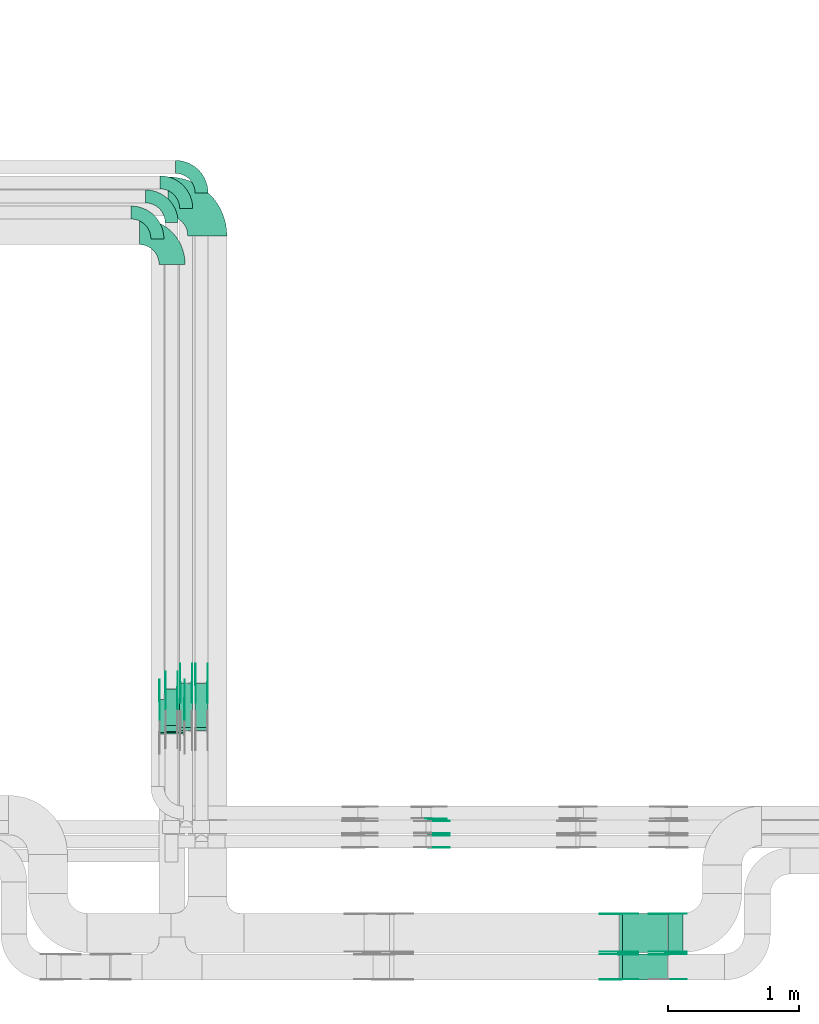
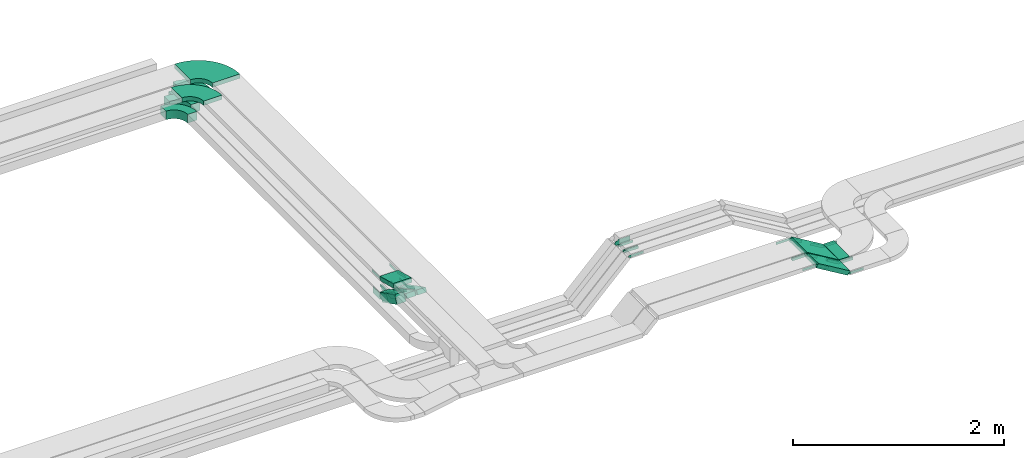
# One storey, part 17 of 19: 42 flow fittings, 7 flow segments.
"""IFC2X3 building model written with IfcOpenShell, lengths in millimetres."""

from ifc_helpers import new_model, entity, si_unit, converted_unit, derived_unit, direction, frame, frame_2d, origin, origin_2d_with_axis, place, context, subcontext, project, spatial, polyline, circle_curve, parameter, trimmed, segment, composite_curve, rectangle, outline, extrude, source, transform, mapped, material, type_object, type_shapes, element, save


model = new_model("IFC2X3")

# Units and contexts
model_context = context("Model", 3, precision=0.01, world=origin(), true_north=direction((6.12303176911189e-17, 1.0)))
body_context = subcontext(model_context, "Body", "Model", "MODEL_VIEW")
ifc_project = project(units=[si_unit("LENGTHUNIT", "METRE", prefix="MILLI"), si_unit("AREAUNIT", "SQUARE_METRE"), si_unit("VOLUMEUNIT", "CUBIC_METRE"), converted_unit("PLANEANGLEUNIT", "DEGREE", entity("IfcRatioMeasure", 0.0174532925199433), si_unit("PLANEANGLEUNIT", "RADIAN"), dimensions=[0, 0, 0, 0, 0, 0, 0]), si_unit("MASSUNIT", "GRAM", prefix="KILO"), derived_unit("MASSDENSITYUNIT", [(si_unit("MASSUNIT", "GRAM", prefix="KILO"), 1), (si_unit("LENGTHUNIT", "METRE"), -3)]), derived_unit("MOMENTOFINERTIAUNIT", [(si_unit("LENGTHUNIT", "METRE"), 4)]), si_unit("TIMEUNIT", "SECOND"), si_unit("FREQUENCYUNIT", "HERTZ"), si_unit("THERMODYNAMICTEMPERATUREUNIT", "DEGREE_CELSIUS"), derived_unit("THERMALTRANSMITTANCEUNIT", [(si_unit("MASSUNIT", "GRAM", prefix="KILO"), 1), (si_unit("THERMODYNAMICTEMPERATUREUNIT", "KELVIN"), -1), (si_unit("TIMEUNIT", "SECOND"), -3)]), derived_unit("VOLUMETRICFLOWRATEUNIT", [(si_unit("LENGTHUNIT", "METRE"), 3), (si_unit("TIMEUNIT", "SECOND"), -1)]), derived_unit("MASSFLOWRATEUNIT", [(si_unit("MASSUNIT", "GRAM", prefix="KILO"), 1), (si_unit("TIMEUNIT", "SECOND"), -1)]), derived_unit("ROTATIONALFREQUENCYUNIT", [(si_unit("TIMEUNIT", "SECOND"), -1)]), si_unit("ELECTRICCURRENTUNIT", "AMPERE"), si_unit("ELECTRICVOLTAGEUNIT", "VOLT"), si_unit("POWERUNIT", "WATT"), si_unit("FORCEUNIT", "NEWTON", prefix="KILO"), si_unit("ILLUMINANCEUNIT", "LUX"), si_unit("LUMINOUSFLUXUNIT", "LUMEN"), si_unit("LUMINOUSINTENSITYUNIT", "CANDELA"), derived_unit("USERDEFINED", [(si_unit("MASSUNIT", "GRAM", prefix="KILO"), -1), (si_unit("LENGTHUNIT", "METRE"), -2), (si_unit("TIMEUNIT", "SECOND"), 3), (si_unit("LUMINOUSFLUXUNIT", "LUMEN"), 1)]), derived_unit("LINEARVELOCITYUNIT", [(si_unit("LENGTHUNIT", "METRE"), 1), (si_unit("TIMEUNIT", "SECOND"), -1)]), si_unit("PRESSUREUNIT", "PASCAL"), derived_unit("USERDEFINED", [(si_unit("LENGTHUNIT", "METRE"), -2), (si_unit("MASSUNIT", "GRAM", prefix="KILO"), 1), (si_unit("TIMEUNIT", "SECOND"), -2)]), derived_unit("LINEARFORCEUNIT", [(si_unit("MASSUNIT", "GRAM", prefix="KILO"), 1), (si_unit("LENGTHUNIT", "METRE"), 1), (si_unit("TIMEUNIT", "SECOND"), -2), (si_unit("LENGTHUNIT", "METRE"), -1)]), derived_unit("PLANARFORCEUNIT", [(si_unit("MASSUNIT", "GRAM", prefix="KILO"), 1), (si_unit("LENGTHUNIT", "METRE"), 1), (si_unit("TIMEUNIT", "SECOND"), -2), (si_unit("LENGTHUNIT", "METRE"), -2)])], contexts=[model_context])

# Site, building, storey
site_placement = place(None, origin())
site = spatial("IfcSite", under=ifc_project, at=site_placement, CompositionType="ELEMENT")
building_placement = place(site_placement, origin())
building = spatial("IfcBuilding", under=site, at=building_placement, CompositionType="ELEMENT")
storey_placement = place(building_placement, frame((0.0, 0.0, 12000.0)))
storey = spatial("IfcBuildingStorey", under=building, at=storey_placement, CompositionType="ELEMENT", Elevation=12000.0)

# Flow segments
cable_carrier_segment_type = type_object("IfcCableCarrierSegmentType", PredefinedType="CABLETRAYSEGMENT")
flow_segment_1_placement = place(storey_placement, frame((60138.97, 10518.86, 2511.79)))
element("IfcFlowSegment", 1, at=flow_segment_1_placement, inside=storey, type_object=cable_carrier_segment_type, context=body_context, shape_type="SweptSolid", body=[
    extrude(rectangle(XDim=99.9999999999996, YDim=313.488330030498, at=frame_2d((0.0, 0.0), x_axis=(0.0, 1.0))), frame((0.0, 162.36, 115.71), z_axis=(1.0, 0.0, 0.0), x_axis=(0.0, -0.891006524188386, 0.453990499739511)), (0.0, 0.0, 1.0), 100.000000000003),
])
flow_segment_2_placement = place(storey_placement, frame((60250.78, 10524.87, 2506.34)))
element("IfcFlowSegment", 2, at=flow_segment_2_placement, inside=storey, type_object=cable_carrier_segment_type, context=body_context, shape_type="SweptSolid", body=[
    extrude(rectangle(XDim=50.0000000000023, YDim=380.5594995989, at=frame_2d((0.0, 0.0), x_axis=(0.0, 1.0))), frame((0.0, 180.89, 108.66), z_axis=(1.0, 0.0, 0.0), x_axis=(0.0, -0.891006524188355, 0.453990499739573)), (0.0, 0.0, 1.0), 99.9999999999946),
])
flow_segment_3_placement = place(storey_placement, frame((60368.35, 10524.87, 2506.34)))
element("IfcFlowSegment", 3, at=flow_segment_3_placement, inside=storey, type_object=cable_carrier_segment_type, context=body_context, shape_type="SweptSolid", body=[
    extrude(rectangle(XDim=50.0000000000023, YDim=380.559499598904, at=frame_2d((0.0, 0.0), x_axis=(0.0, 1.0))), frame((0.0, 180.89, 108.66), z_axis=(1.0, 0.0, 0.0), x_axis=(0.0, -0.891006524188357, 0.453990499739568)), (0.0, 0.0, 1.0), 99.9999999999945),
])
flow_segment_4_placement = place(storey_placement, frame((60092.55, 10497.93, 2802.1)))
element("IfcFlowSegment", 4, at=flow_segment_4_placement, inside=storey, type_object=cable_carrier_segment_type, context=body_context, shape_type="SweptSolid", body=[
    extrude(rectangle(XDim=49.999999999998, YDim=260.823386500712, at=frame_2d((0.0, 0.0), x_axis=(0.0, 1.0))), frame((0.0, 132.44, 57.9), z_axis=(1.0, 0.0, 0.0), x_axis=(0.0, -0.965925826289048, 0.258819045102596)), (0.0, 0.0, 1.0), 200.000000000006),
])
flow_segment_5_placement = place(storey_placement, frame((63618.5, 8824.99, 2808.17)))
element("IfcFlowSegment", 5, at=flow_segment_5_placement, inside=storey, type_object=cable_carrier_segment_type, context=body_context, shape_type="SweptSolid", body=[
    extrude(rectangle(XDim=49.9999999999925, YDim=299.999999999999, at=frame_2d((0.0, 0.0), x_axis=(0.0, 1.0))), frame((12.83, 150.0, 227.2), z_axis=(0.858170923011643, 0.0, -0.513364068568637), x_axis=(0.0, 1.0, 0.0)), (0.0, 0.0, 1.0), 400.782208952029),
])
flow_segment_6_placement = place(storey_placement, frame((63618.51, 8613.82, 2808.17)))
element("IfcFlowSegment", 6, at=flow_segment_6_placement, inside=storey, type_object=cable_carrier_segment_type, context=body_context, shape_type="SweptSolid", body=[
    extrude(rectangle(XDim=49.9999999999925, YDim=200.0, at=frame_2d((0.0, 0.0), x_axis=(0.0, 1.0))), frame((12.83, 100.0, 227.2), z_axis=(0.858170923011643, 0.0, -0.513364068568637), x_axis=(0.0, 1.0, 0.0)), (0.0, 0.0, 1.0), 400.773438719208),
])
flow_segment_7_placement = place(storey_placement, frame((63992.02, 8824.99, 2800.0)))
element("IfcFlowSegment", 7, at=flow_segment_7_placement, inside=storey, type_object=cable_carrier_segment_type, context=body_context, shape_type="SweptSolid", body=[
    extrude(rectangle(XDim=113.412526248783, YDim=300.000000000001, at=origin_2d_with_axis()), frame((56.71, 150.0, 0.0)), (0.0, 0.0, 1.0), 49.9999999999995),
])

# Flow fittings
ifc_material_1 = material()
cable_carrier_fitting_type_1 = type_object("IfcCableCarrierFittingType", Name="470_DKC_S5_Variable Angle Elbow 0-45:-", PredefinedType="NOTDEFINED", material=ifc_material_1)
shared_shape_1 = source(origin(), body_context, "Body", "SweptSolid", [
    extrude(outline(composite_curve([segment(polyline([(-150.75, -300.25), (-149.75, -300.25)]), True, "CONTINUOUS"), segment(trimmed(circle_curve(frame_2d((-149.75, 149.75), x_axis=(0.0, -1.0)), 450.0), [parameter(0.0)], [parameter(90.0000000000001)], True, "PARAMETER"), True, "CONTINUOUS"), segment(polyline([(300.25, 149.75), (300.25, 150.75)]), True, "CONTINUOUS"), segment(polyline([(300.25, 150.75), (0.25, 150.75)]), True, "CONTINUOUS"), segment(polyline([(0.25, 150.75), (0.25, 149.75)]), True, "CONTINUOUS"), segment(trimmed(circle_curve(frame_2d((-149.75, 149.75), x_axis=(0.0, -1.0)), 150.0), [parameter(0.0)], [parameter(90.0000000000001)], True, "PARAMETER"), False, "CONTINUOUS"), segment(polyline([(-149.75, -0.25), (-150.75, -0.25)]), True, "CONTINUOUS"), segment(polyline([(-150.75, -0.25), (-150.75, -300.25)]), True, "CONTINUOUS")], self_intersect=False)), frame((-150.25, 150.25, -25.0)), (0.0, 0.0, 1.0), 49.9999999999974),
])
type_shapes(cable_carrier_fitting_type_1, [shared_shape_1])
flow_fitting_1_placement = place(storey_placement, frame((60462.55, 14615.22, 2825.0), z_axis=(0.0, 0.0, 1.0), x_axis=(0.0, 1.0, 0.0)))
element("IfcFlowFitting", 8, at=flow_fitting_1_placement, inside=storey, type_object=cable_carrier_fitting_type_1, material=ifc_material_1, Name="470_DKC_S5_Variable Angle Elbow 0-45:-", ObjectType="470_DKC_S5_Variable Angle Elbow 0-45:-", context=body_context, shape_type="MappedRepresentation", body=[
    mapped(shared_shape_1, transform((0.0, 0.0, 0.0), scale=1.0)),
])
cable_carrier_fitting_type_2 = type_object("IfcCableCarrierFittingType", Name="470_DKC_S5_Variable Angle Elbow 0-45:-", PredefinedType="NOTDEFINED", material=ifc_material_1)
shared_shape_2 = source(origin(), body_context, "Body", "SweptSolid", [
    extrude(outline(composite_curve([segment(polyline([(-100.75, -150.25), (-99.75, -150.25)]), True, "CONTINUOUS"), segment(trimmed(circle_curve(frame_2d((-99.75, 99.75), x_axis=(0.0, -1.0)), 250.0), [parameter(0.0)], [parameter(90.0000000000001)], True, "PARAMETER"), True, "CONTINUOUS"), segment(polyline([(150.25, 99.75), (150.25, 100.75)]), True, "CONTINUOUS"), segment(polyline([(150.25, 100.75), (50.25, 100.75)]), True, "CONTINUOUS"), segment(polyline([(50.25, 100.75), (50.25, 99.75)]), True, "CONTINUOUS"), segment(trimmed(circle_curve(frame_2d((-99.75, 99.75), x_axis=(0.0, -1.0)), 150.0), [parameter(0.0)], [parameter(90.0000000000001)], True, "PARAMETER"), False, "CONTINUOUS"), segment(polyline([(-99.75, -50.25), (-100.75, -50.25)]), True, "CONTINUOUS"), segment(polyline([(-100.75, -50.25), (-100.75, -150.25)]), True, "CONTINUOUS")], self_intersect=False)), frame((-100.25, 100.25, -25.0)), (0.0, 0.0, 1.0), 49.9999999999997),
])
type_shapes(cable_carrier_fitting_type_2, [shared_shape_2])
for number, where, z_axis, x_axis, name in (
    (9, (60418.35, 14842.5, 2525.0), (0.0, 0.0, 1.0), (0.0, 1.0, 0.0), "470_DKC_S5_Variable Angle Elbow 0-45:-"),
    (10, (60300.78, 14723.63, 2525.0), (0.0, 0.0, 1.0), (0.0, 1.0, 0.0), "470_DKC_S5_Variable Angle Elbow 0-45:-"),
):
    element("IfcFlowFitting", number, at=place(storey_placement, frame(where, z_axis=z_axis, x_axis=x_axis)), inside=storey, type_object=cable_carrier_fitting_type_2, material=ifc_material_1, Name=name, ObjectType="470_DKC_S5_Variable Angle Elbow 0-45:-", context=body_context, shape_type="MappedRepresentation", body=[
        mapped(shared_shape_2, transform((0.0, 0.0, 0.0), scale=1.0)),
    ])
ifc_material_2 = material(Name="G")
cable_carrier_fitting_type_3 = type_object("IfcCableCarrierFittingType", PredefinedType="NOTDEFINED", material=ifc_material_2)
shared_shape_3 = source(origin(), body_context, "Body", "SweptSolid", [
    extrude(outline(composite_curve([segment(trimmed(circle_curve(frame_2d((-44.59, 0.0), x_axis=(1.0, 0.0)), 12.5), [parameter(90.0000000000007)], [parameter(270.0)], True, "PARAMETER"), True, "CONTINUOUS"), segment(polyline([(-44.59, -12.5), (-33.09, -12.5)]), True, "CONTINUOUS"), segment(polyline([(-33.09, -12.5), (-31.23, -14.5)]), True, "CONTINUOUS"), segment(polyline([(-31.23, -14.5), (108.91, -14.5)]), True, "CONTINUOUS"), segment(polyline([(108.91, -14.5), (108.91, 14.5)]), True, "CONTINUOUS"), segment(polyline([(108.91, 14.5), (-31.23, 14.5)]), True, "CONTINUOUS"), segment(polyline([(-31.23, 14.5), (-33.09, 12.5)]), True, "CONTINUOUS"), segment(polyline([(-33.09, 12.5), (-44.59, 12.5)]), True, "CONTINUOUS")], self_intersect=False)), frame((44.59, 0.0, 0.0), z_axis=(0.0, 0.0, -1.0), x_axis=(1.0, 0.0, 0.0)), (0.0, 0.0, -1.0), 2.0),
])
type_shapes(cable_carrier_fitting_type_3, [shared_shape_3])
for number, where, z_axis, x_axis in (
    (11, (62165.35, 9830.45, 3040.0), (0.0, 1.0, 0.0), (1.0, 0.0, 0.0)),
    (12, (63623.6, 9120.45, 3040.0), (0.0, 1.0, 0.0), (0.858170923011649, 0.0, -0.513364068568627)),
):
    element("IfcFlowFitting", number, at=place(storey_placement, frame(where, z_axis=z_axis, x_axis=x_axis)), inside=storey, type_object=cable_carrier_fitting_type_3, material=ifc_material_2, context=body_context, shape_type="MappedRepresentation", body=[
        mapped(shared_shape_3, transform((0.0, 0.0, 0.0), scale=1.0)),
    ])
cable_carrier_fitting_type_4 = type_object("IfcCableCarrierFittingType", PredefinedType="NOTDEFINED", material=ifc_material_2)
type_shapes(cable_carrier_fitting_type_4, [shared_shape_3])
flow_fitting_2_placement = place(storey_placement, frame((63623.6, 8831.53, 3040.0), z_axis=(0.0, -1.0, 0.0), x_axis=(-1.0, 0.0, 0.0)))
element("IfcFlowFitting", 13, at=flow_fitting_2_placement, inside=storey, type_object=cable_carrier_fitting_type_4, material=ifc_material_2, context=body_context, shape_type="MappedRepresentation", body=[
    mapped(shared_shape_3, transform((0.0, 0.0, 0.0), scale=1.0)),
])
flow_fitting_3_placement = place(storey_placement, frame((63623.61, 8618.36, 3040.0), z_axis=(0.0, -1.0, 0.0), x_axis=(-1.0, 0.0, 0.0)))
element("IfcFlowFitting", 14, at=flow_fitting_3_placement, inside=storey, type_object=cable_carrier_fitting_type_3, material=ifc_material_2, context=body_context, shape_type="MappedRepresentation", body=[
    mapped(shared_shape_3, transform((0.0, 0.0, 0.0), scale=1.0)),
])
flow_fitting_4_placement = place(storey_placement, frame((63623.61, 8807.28, 3040.0), z_axis=(0.0, 1.0, 0.0), x_axis=(0.858170923011644, 0.0, -0.513364068568636)))
element("IfcFlowFitting", 15, at=flow_fitting_4_placement, inside=storey, type_object=cable_carrier_fitting_type_4, material=ifc_material_2, context=body_context, shape_type="MappedRepresentation", body=[
    mapped(shared_shape_3, transform((0.0, 0.0, 0.0), scale=1.0)),
])
flow_fitting_5_placement = place(storey_placement, frame((60463.81, 10882.39, 2525.0), z_axis=(1.0, 0.0, 0.0), x_axis=(0.0, 1.0, 0.0)))
element("IfcFlowFitting", 16, at=flow_fitting_5_placement, inside=storey, type_object=cable_carrier_fitting_type_3, material=ifc_material_2, context=body_context, shape_type="MappedRepresentation", body=[
    mapped(shared_shape_3, transform((0.0, 0.0, 0.0), scale=1.0)),
])
flow_fitting_6_placement = place(storey_placement, frame((60374.89, 10882.39, 2525.0), z_axis=(-1.0, 0.0, 0.0), x_axis=(0.0, -0.891006524188381, 0.453990499739522)))
element("IfcFlowFitting", 17, at=flow_fitting_6_placement, inside=storey, type_object=cable_carrier_fitting_type_4, material=ifc_material_2, context=body_context, shape_type="MappedRepresentation", body=[
    mapped(shared_shape_3, transform((0.0, 0.0, 0.0), scale=1.0)),
])
flow_fitting_7_placement = place(storey_placement, frame((60346.24, 10882.39, 2525.0), z_axis=(1.0, 0.0, 0.0), x_axis=(0.0, 1.0, 0.0)))
element("IfcFlowFitting", 18, at=flow_fitting_7_placement, inside=storey, type_object=cable_carrier_fitting_type_3, material=ifc_material_2, context=body_context, shape_type="MappedRepresentation", body=[
    mapped(shared_shape_3, transform((0.0, 0.0, 0.0), scale=1.0)),
])
flow_fitting_8_placement = place(storey_placement, frame((60257.32, 10882.39, 2525.0), z_axis=(-1.0, 0.0, 0.0), x_axis=(0.0, -0.891006524188381, 0.453990499739522)))
element("IfcFlowFitting", 19, at=flow_fitting_8_placement, inside=storey, type_object=cable_carrier_fitting_type_4, material=ifc_material_2, context=body_context, shape_type="MappedRepresentation", body=[
    mapped(shared_shape_3, transform((0.0, 0.0, 0.0), scale=1.0)),
])
flow_fitting_9_placement = place(storey_placement, frame((60288.01, 10760.99, 2825.0), z_axis=(1.0, 0.0, 0.0), x_axis=(0.0, 1.0, 0.0)))
element("IfcFlowFitting", 20, at=flow_fitting_9_placement, inside=storey, type_object=cable_carrier_fitting_type_3, material=ifc_material_2, context=body_context, shape_type="MappedRepresentation", body=[
    mapped(shared_shape_3, transform((0.0, 0.0, 0.0), scale=1.0)),
])
flow_fitting_10_placement = place(storey_placement, frame((60099.09, 10760.99, 2825.0), z_axis=(-1.0, 0.0, 0.0), x_axis=(0.0, -0.965925826289068, 0.258819045102522)))
element("IfcFlowFitting", 21, at=flow_fitting_10_placement, inside=storey, type_object=cable_carrier_fitting_type_4, material=ifc_material_2, context=body_context, shape_type="MappedRepresentation", body=[
    mapped(shared_shape_3, transform((0.0, 0.0, 0.0), scale=1.0)),
])
for number, where, z_axis, x_axis in (
    (22, (62165.35, 9720.45, 3040.0), (0.0, 1.0, 0.0), (1.0, 0.0, 0.0)),
    (23, (63983.01, 8829.53, 2825.0), (0.0, -1.0, 0.0), (1.0, 0.0, 0.0)),
):
    element("IfcFlowFitting", number, at=place(storey_placement, frame(where, z_axis=z_axis, x_axis=x_axis)), inside=storey, type_object=cable_carrier_fitting_type_3, material=ifc_material_2, context=body_context, shape_type="MappedRepresentation", body=[
        mapped(shared_shape_3, transform((0.0, 0.0, 0.0), scale=1.0)),
    ])
flow_fitting_11_placement = place(storey_placement, frame((63983.01, 9118.45, 2825.0), z_axis=(0.0, 1.0, 0.0), x_axis=(-0.858170923011648, 0.0, 0.51336406856863)))
element("IfcFlowFitting", 24, at=flow_fitting_11_placement, inside=storey, type_object=cable_carrier_fitting_type_4, material=ifc_material_2, context=body_context, shape_type="MappedRepresentation", body=[
    mapped(shared_shape_3, transform((0.0, 0.0, 0.0), scale=1.0)),
])
flow_fitting_12_placement = place(storey_placement, frame((63983.01, 8618.36, 2825.0), z_axis=(0.0, -1.0, 0.0), x_axis=(1.0, 0.0, 0.0)))
element("IfcFlowFitting", 25, at=flow_fitting_12_placement, inside=storey, type_object=cable_carrier_fitting_type_3, material=ifc_material_2, context=body_context, shape_type="MappedRepresentation", body=[
    mapped(shared_shape_3, transform((0.0, 0.0, 0.0), scale=1.0)),
])
flow_fitting_13_placement = place(storey_placement, frame((63983.01, 8807.28, 2825.0), z_axis=(0.0, 1.0, 0.0), x_axis=(-0.858170923011649, 0.0, 0.513364068568627)))
element("IfcFlowFitting", 26, at=flow_fitting_13_placement, inside=storey, type_object=cable_carrier_fitting_type_4, material=ifc_material_2, context=body_context, shape_type="MappedRepresentation", body=[
    mapped(shared_shape_3, transform((0.0, 0.0, 0.0), scale=1.0)),
])
cable_carrier_fitting_type_5 = type_object("IfcCableCarrierFittingType", PredefinedType="NOTDEFINED", material=ifc_material_2)
shared_shape_4 = source(origin(), body_context, "Body", "SweptSolid", [
    extrude(outline(composite_curve([segment(trimmed(circle_curve(frame_2d((-44.59, 0.0), x_axis=(1.0, 0.0)), 12.5), [parameter(90.0000000000007)], [parameter(270.0)], True, "PARAMETER"), True, "CONTINUOUS"), segment(polyline([(-44.59, -12.5), (-33.09, -12.5)]), True, "CONTINUOUS"), segment(polyline([(-33.09, -12.5), (-31.23, -14.5)]), True, "CONTINUOUS"), segment(polyline([(-31.23, -14.5), (108.91, -14.5)]), True, "CONTINUOUS"), segment(polyline([(108.91, -14.5), (108.91, 14.5)]), True, "CONTINUOUS"), segment(polyline([(108.91, 14.5), (-31.23, 14.5)]), True, "CONTINUOUS"), segment(polyline([(-31.23, 14.5), (-33.09, 12.5)]), True, "CONTINUOUS"), segment(polyline([(-33.09, 12.5), (-44.59, 12.5)]), True, "CONTINUOUS")], self_intersect=False)), frame((44.59, 0.0, 0.0)), (0.0, 0.0, 1.0), 2.0),
])
type_shapes(cable_carrier_fitting_type_5, [shared_shape_4])
for number, where, z_axis, x_axis in (
    (27, (62165.35, 9739.53, 3040.0), (0.0, -1.0, 0.0), (1.0, 0.0, 0.0)),
    (28, (63623.6, 8829.53, 3040.0), (0.0, -1.0, 0.0), (0.858170923011649, 0.0, -0.513364068568627)),
):
    element("IfcFlowFitting", number, at=place(storey_placement, frame(where, z_axis=z_axis, x_axis=x_axis)), inside=storey, type_object=cable_carrier_fitting_type_5, material=ifc_material_2, context=body_context, shape_type="MappedRepresentation", body=[
        mapped(shared_shape_4, transform((0.0, 0.0, 0.0), scale=1.0)),
    ])
cable_carrier_fitting_type_6 = type_object("IfcCableCarrierFittingType", PredefinedType="NOTDEFINED", material=ifc_material_2)
type_shapes(cable_carrier_fitting_type_6, [shared_shape_4])
flow_fitting_14_placement = place(storey_placement, frame((63623.6, 9118.45, 3040.0), z_axis=(0.0, 1.0, 0.0), x_axis=(-1.0, 0.0, 0.0)))
element("IfcFlowFitting", 29, at=flow_fitting_14_placement, inside=storey, type_object=cable_carrier_fitting_type_6, material=ifc_material_2, context=body_context, shape_type="MappedRepresentation", body=[
    mapped(shared_shape_4, transform((0.0, 0.0, 0.0), scale=1.0)),
])
flow_fitting_15_placement = place(storey_placement, frame((63623.61, 8809.28, 3040.0), z_axis=(0.0, 1.0, 0.0), x_axis=(-1.0, 0.0, 0.0)))
element("IfcFlowFitting", 30, at=flow_fitting_15_placement, inside=storey, type_object=cable_carrier_fitting_type_5, material=ifc_material_2, context=body_context, shape_type="MappedRepresentation", body=[
    mapped(shared_shape_4, transform((0.0, 0.0, 0.0), scale=1.0)),
])
flow_fitting_16_placement = place(storey_placement, frame((63623.61, 8620.36, 3040.0), z_axis=(0.0, -1.0, 0.0), x_axis=(0.858170923011644, 0.0, -0.513364068568636)))
element("IfcFlowFitting", 31, at=flow_fitting_16_placement, inside=storey, type_object=cable_carrier_fitting_type_6, material=ifc_material_2, context=body_context, shape_type="MappedRepresentation", body=[
    mapped(shared_shape_4, transform((0.0, 0.0, 0.0), scale=1.0)),
])
flow_fitting_17_placement = place(storey_placement, frame((60372.89, 10882.39, 2525.0), z_axis=(-1.0, 0.0, 0.0), x_axis=(0.0, 1.0, 0.0)))
element("IfcFlowFitting", 32, at=flow_fitting_17_placement, inside=storey, type_object=cable_carrier_fitting_type_5, material=ifc_material_2, context=body_context, shape_type="MappedRepresentation", body=[
    mapped(shared_shape_4, transform((0.0, 0.0, 0.0), scale=1.0)),
])
flow_fitting_18_placement = place(storey_placement, frame((60461.81, 10882.39, 2525.0), z_axis=(1.0, 0.0, 0.0), x_axis=(0.0, -0.891006524188381, 0.453990499739522)))
element("IfcFlowFitting", 33, at=flow_fitting_18_placement, inside=storey, type_object=cable_carrier_fitting_type_6, material=ifc_material_2, context=body_context, shape_type="MappedRepresentation", body=[
    mapped(shared_shape_4, transform((0.0, 0.0, 0.0), scale=1.0)),
])
flow_fitting_19_placement = place(storey_placement, frame((60255.32, 10882.39, 2525.0), z_axis=(-1.0, 0.0, 0.0), x_axis=(0.0, 1.0, 0.0)))
element("IfcFlowFitting", 34, at=flow_fitting_19_placement, inside=storey, type_object=cable_carrier_fitting_type_5, material=ifc_material_2, context=body_context, shape_type="MappedRepresentation", body=[
    mapped(shared_shape_4, transform((0.0, 0.0, 0.0), scale=1.0)),
])
flow_fitting_20_placement = place(storey_placement, frame((60344.24, 10882.39, 2525.0), z_axis=(1.0, 0.0, 0.0), x_axis=(0.0, -0.891006524188381, 0.453990499739522)))
element("IfcFlowFitting", 35, at=flow_fitting_20_placement, inside=storey, type_object=cable_carrier_fitting_type_6, material=ifc_material_2, context=body_context, shape_type="MappedRepresentation", body=[
    mapped(shared_shape_4, transform((0.0, 0.0, 0.0), scale=1.0)),
])
flow_fitting_21_placement = place(storey_placement, frame((60097.09, 10760.99, 2825.0), z_axis=(-1.0, 0.0, 0.0), x_axis=(0.0, 1.0, 0.0)))
element("IfcFlowFitting", 36, at=flow_fitting_21_placement, inside=storey, type_object=cable_carrier_fitting_type_5, material=ifc_material_2, context=body_context, shape_type="MappedRepresentation", body=[
    mapped(shared_shape_4, transform((0.0, 0.0, 0.0), scale=1.0)),
])
flow_fitting_22_placement = place(storey_placement, frame((60286.01, 10760.99, 2825.0), z_axis=(1.0, 0.0, 0.0), x_axis=(0.0, -0.965925826289068, 0.258819045102522)))
element("IfcFlowFitting", 37, at=flow_fitting_22_placement, inside=storey, type_object=cable_carrier_fitting_type_6, material=ifc_material_2, context=body_context, shape_type="MappedRepresentation", body=[
    mapped(shared_shape_4, transform((0.0, 0.0, 0.0), scale=1.0)),
])
for number, where, z_axis, x_axis in (
    (38, (62165.35, 9629.53, 3040.0), (0.0, -1.0, 0.0), (1.0, 0.0, 0.0)),
    (39, (63983.01, 9120.45, 2825.0), (0.0, 1.0, 0.0), (1.0, 0.0, 0.0)),
):
    element("IfcFlowFitting", number, at=place(storey_placement, frame(where, z_axis=z_axis, x_axis=x_axis)), inside=storey, type_object=cable_carrier_fitting_type_5, material=ifc_material_2, context=body_context, shape_type="MappedRepresentation", body=[
        mapped(shared_shape_4, transform((0.0, 0.0, 0.0), scale=1.0)),
    ])
flow_fitting_23_placement = place(storey_placement, frame((63983.01, 8831.53, 2825.0), z_axis=(0.0, -1.0, 0.0), x_axis=(-0.858170923011648, 0.0, 0.51336406856863)))
element("IfcFlowFitting", 40, at=flow_fitting_23_placement, inside=storey, type_object=cable_carrier_fitting_type_6, material=ifc_material_2, context=body_context, shape_type="MappedRepresentation", body=[
    mapped(shared_shape_4, transform((0.0, 0.0, 0.0), scale=1.0)),
])
flow_fitting_24_placement = place(storey_placement, frame((63983.01, 8809.28, 2825.0), z_axis=(0.0, 1.0, 0.0), x_axis=(1.0, 0.0, 0.0)))
element("IfcFlowFitting", 41, at=flow_fitting_24_placement, inside=storey, type_object=cable_carrier_fitting_type_5, material=ifc_material_2, context=body_context, shape_type="MappedRepresentation", body=[
    mapped(shared_shape_4, transform((0.0, 0.0, 0.0), scale=1.0)),
])
cable_carrier_fitting_type_7 = type_object("IfcCableCarrierFittingType", Name="470_DKC_S5_Variable Angle Elbow 0-45:-", PredefinedType="NOTDEFINED", material=ifc_material_1)
shared_shape_5 = source(origin(), body_context, "Body", "SweptSolid", [
    extrude(outline(composite_curve([segment(polyline([(-100.75, -150.25), (-99.75, -150.25)]), True, "CONTINUOUS"), segment(trimmed(circle_curve(frame_2d((-99.75, 99.75), x_axis=(0.0, -1.0)), 250.0), [parameter(0.0)], [parameter(90.0000000000001)], True, "PARAMETER"), True, "CONTINUOUS"), segment(polyline([(150.25, 99.75), (150.25, 100.75)]), True, "CONTINUOUS"), segment(polyline([(150.25, 100.75), (50.25, 100.75)]), True, "CONTINUOUS"), segment(polyline([(50.25, 100.75), (50.25, 99.75)]), True, "CONTINUOUS"), segment(trimmed(circle_curve(frame_2d((-99.75, 99.75), x_axis=(0.0, -1.0)), 150.0), [parameter(0.0)], [parameter(90.0000000000001)], True, "PARAMETER"), False, "CONTINUOUS"), segment(polyline([(-99.75, -50.25), (-100.75, -50.25)]), True, "CONTINUOUS"), segment(polyline([(-100.75, -50.25), (-100.75, -150.25)]), True, "CONTINUOUS")], self_intersect=False)), frame((-100.25, 100.25, -50.0)), (0.0, 0.0, 1.0), 100.0),
])
type_shapes(cable_carrier_fitting_type_7, [shared_shape_5])
for number, where, z_axis, x_axis, name in (
    (42, (60188.97, 14616.24, 2550.0), (0.0, 0.0, 1.0), (0.0, 1.0, 0.0), "470_DKC_S5_Variable Angle Elbow 0-45:-"),
    (43, (60080.0, 14492.5, 2550.0), (0.0, 0.0, 1.0), (0.0, 1.0, 0.0), "470_DKC_S5_Variable Angle Elbow 0-45:-"),
):
    element("IfcFlowFitting", number, at=place(storey_placement, frame(where, z_axis=z_axis, x_axis=x_axis)), inside=storey, type_object=cable_carrier_fitting_type_7, material=ifc_material_1, Name=name, ObjectType="470_DKC_S5_Variable Angle Elbow 0-45:-", context=body_context, shape_type="MappedRepresentation", body=[
        mapped(shared_shape_5, transform((0.0, 0.0, 0.0), scale=1.0)),
    ])
cable_carrier_fitting_type_8 = type_object("IfcCableCarrierFittingType", Name="470_DKC_S5_Variable Angle Elbow 0-45:-", PredefinedType="NOTDEFINED", material=ifc_material_1)
shared_shape_6 = source(origin(), body_context, "Body", "SweptSolid", [
    extrude(outline(composite_curve([segment(polyline([(-125.75, -225.25), (-124.75, -225.25)]), True, "CONTINUOUS"), segment(trimmed(circle_curve(frame_2d((-124.75, 124.75), x_axis=(0.0, -1.0)), 350.0), [parameter(0.0)], [parameter(90.0000000000001)], True, "PARAMETER"), True, "CONTINUOUS"), segment(polyline([(225.25, 124.75), (225.25, 125.75)]), True, "CONTINUOUS"), segment(polyline([(225.25, 125.75), (25.25, 125.75)]), True, "CONTINUOUS"), segment(polyline([(25.25, 125.75), (25.25, 124.75)]), True, "CONTINUOUS"), segment(trimmed(circle_curve(frame_2d((-124.75, 124.75), x_axis=(0.0, -1.0)), 150.0), [parameter(0.0)], [parameter(90.0000000000001)], True, "PARAMETER"), False, "CONTINUOUS"), segment(polyline([(-124.75, -25.25), (-125.75, -25.25)]), True, "CONTINUOUS"), segment(polyline([(-125.75, -25.25), (-125.75, -225.25)]), True, "CONTINUOUS")], self_intersect=False)), frame((-125.25, 125.25, -25.0)), (0.0, 0.0, 1.0), 50.000000000001),
])
type_shapes(cable_carrier_fitting_type_8, [shared_shape_6])
flow_fitting_25_placement = place(storey_placement, frame((60192.55, 14347.35, 2825.0), z_axis=(0.0, 0.0, 1.0), x_axis=(0.0, 1.0, 0.0)))
element("IfcFlowFitting", 44, at=flow_fitting_25_placement, inside=storey, type_object=cable_carrier_fitting_type_8, material=ifc_material_1, Name="470_DKC_S5_Variable Angle Elbow 0-45:-", ObjectType="470_DKC_S5_Variable Angle Elbow 0-45:-", context=body_context, shape_type="MappedRepresentation", body=[
    mapped(shared_shape_6, transform((0.0, 0.0, 0.0), scale=1.0)),
])
cable_carrier_fitting_type_9 = type_object("IfcCableCarrierFittingType", PredefinedType="NOTDEFINED", material=ifc_material_2)
shared_shape_7 = source(origin(), body_context, "Body", "SweptSolid", [
    extrude(outline(composite_curve([segment(trimmed(circle_curve(frame_2d((-41.47, 0.0), x_axis=(1.0, 0.0)), 25.0), [parameter(90.0000000000007)], [parameter(270.0)], True, "PARAMETER"), True, "CONTINUOUS"), segment(polyline([(-41.47, -25.0), (-29.97, -25.0)]), True, "CONTINUOUS"), segment(polyline([(-29.97, -25.0), (-28.1, -38.5)]), True, "CONTINUOUS"), segment(polyline([(-28.1, -38.5), (99.53, -38.5)]), True, "CONTINUOUS"), segment(polyline([(99.53, -38.5), (99.53, 38.5)]), True, "CONTINUOUS"), segment(polyline([(99.53, 38.5), (-28.1, 38.5)]), True, "CONTINUOUS"), segment(polyline([(-28.1, 38.5), (-29.97, 25.0)]), True, "CONTINUOUS"), segment(polyline([(-29.97, 25.0), (-41.47, 25.0)]), True, "CONTINUOUS")], self_intersect=False)), frame((41.47, 0.0, 0.0), z_axis=(0.0, 0.0, -1.0), x_axis=(1.0, 0.0, 0.0)), (0.0, 0.0, -1.0), 2.0),
])
type_shapes(cable_carrier_fitting_type_9, [shared_shape_7])
flow_fitting_26_placement = place(storey_placement, frame((60234.43, 10833.33, 2550.0), z_axis=(1.0, 0.0, 0.0), x_axis=(0.0, 1.0, 0.0)))
element("IfcFlowFitting", 45, at=flow_fitting_26_placement, inside=storey, type_object=cable_carrier_fitting_type_9, material=ifc_material_2, context=body_context, shape_type="MappedRepresentation", body=[
    mapped(shared_shape_7, transform((0.0, 0.0, 0.0), scale=1.0)),
])
cable_carrier_fitting_type_10 = type_object("IfcCableCarrierFittingType", PredefinedType="NOTDEFINED", material=ifc_material_2)
type_shapes(cable_carrier_fitting_type_10, [shared_shape_7])
flow_fitting_27_placement = place(storey_placement, frame((60145.51, 10833.33, 2550.0), z_axis=(-1.0, 0.0, 0.0), x_axis=(0.0, -0.891006524188411, 0.453990499739462)))
element("IfcFlowFitting", 46, at=flow_fitting_27_placement, inside=storey, type_object=cable_carrier_fitting_type_10, material=ifc_material_2, context=body_context, shape_type="MappedRepresentation", body=[
    mapped(shared_shape_7, transform((0.0, 0.0, 0.0), scale=1.0)),
])
cable_carrier_fitting_type_11 = type_object("IfcCableCarrierFittingType", PredefinedType="NOTDEFINED", material=ifc_material_2)
shared_shape_8 = source(origin(), body_context, "Body", "SweptSolid", [
    extrude(outline(composite_curve([segment(trimmed(circle_curve(frame_2d((-41.47, 0.0), x_axis=(1.0, 0.0)), 25.0), [parameter(90.0000000000007)], [parameter(270.0)], True, "PARAMETER"), True, "CONTINUOUS"), segment(polyline([(-41.47, -25.0), (-29.97, -25.0)]), True, "CONTINUOUS"), segment(polyline([(-29.97, -25.0), (-28.1, -38.5)]), True, "CONTINUOUS"), segment(polyline([(-28.1, -38.5), (99.53, -38.5)]), True, "CONTINUOUS"), segment(polyline([(99.53, -38.5), (99.53, 38.5)]), True, "CONTINUOUS"), segment(polyline([(99.53, 38.5), (-28.1, 38.5)]), True, "CONTINUOUS"), segment(polyline([(-28.1, 38.5), (-29.97, 25.0)]), True, "CONTINUOUS"), segment(polyline([(-29.97, 25.0), (-41.47, 25.0)]), True, "CONTINUOUS")], self_intersect=False)), frame((41.47, 0.0, 0.0)), (0.0, 0.0, 1.0), 2.0),
])
type_shapes(cable_carrier_fitting_type_11, [shared_shape_8])
for number, where, z_axis, x_axis in (
    (47, (62155.0, 9849.53, 3065.0), (0.0, -1.0, 0.0), (1.0, 0.0, 0.0)),
    (48, (60143.51, 10833.33, 2550.0), (-1.0, 0.0, 0.0), (0.0, 1.0, 0.0)),
):
    element("IfcFlowFitting", number, at=place(storey_placement, frame(where, z_axis=z_axis, x_axis=x_axis)), inside=storey, type_object=cable_carrier_fitting_type_11, material=ifc_material_2, context=body_context, shape_type="MappedRepresentation", body=[
        mapped(shared_shape_8, transform((0.0, 0.0, 0.0), scale=1.0)),
    ])
cable_carrier_fitting_type_12 = type_object("IfcCableCarrierFittingType", PredefinedType="NOTDEFINED", material=ifc_material_2)
type_shapes(cable_carrier_fitting_type_12, [shared_shape_8])
flow_fitting_28_placement = place(storey_placement, frame((60232.43, 10833.33, 2550.0), z_axis=(1.0, 0.0, 0.0), x_axis=(0.0, -0.891006524188411, 0.453990499739462)))
element("IfcFlowFitting", 49, at=flow_fitting_28_placement, inside=storey, type_object=cable_carrier_fitting_type_12, material=ifc_material_2, context=body_context, shape_type="MappedRepresentation", body=[
    mapped(shared_shape_8, transform((0.0, 0.0, 0.0), scale=1.0)),
])

save(model, "model.ifc")
